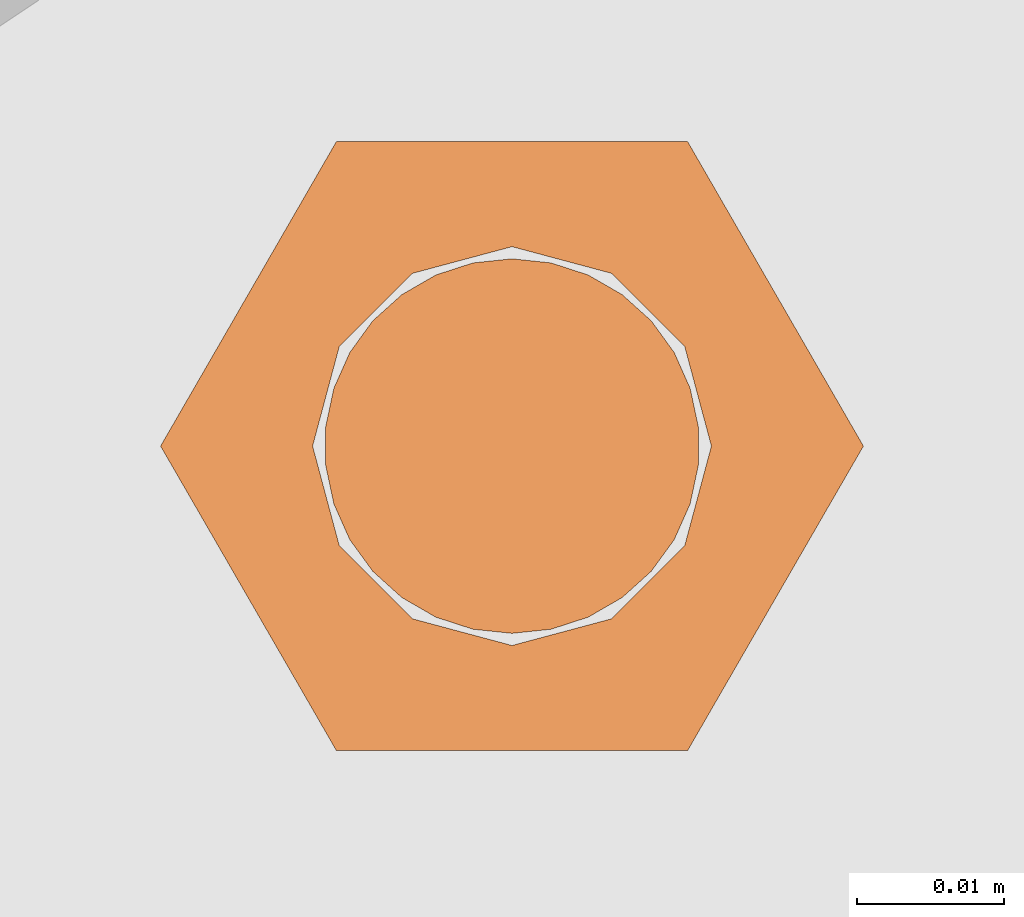
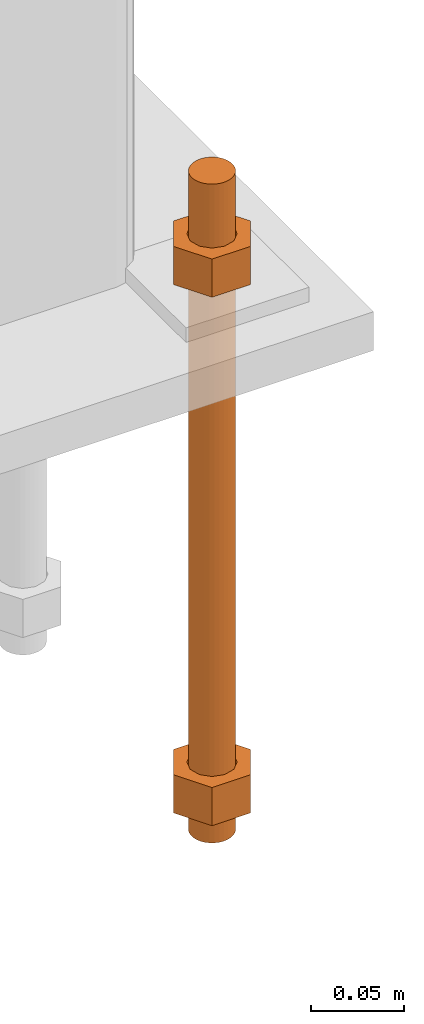
# One storey, part 29 of 89: 1 proxy.
"""IFC4 building model written with IfcOpenShell, lengths in feet."""

from ifc_helpers import new_model, entity, si_unit, converted_unit, derived_unit, direction, frame, origin, place, context, subcontext, project, spatial, faceted_brep, source, transform, mapped, material, constituent, constituent_set, type_object, type_shapes, element, save


model = new_model("IFC4")

# Units and contexts
model_context = context("Model", 3, precision=0.0001, world=origin(), true_north=direction((6.12303176911189e-17, 1.0)))
body_context = subcontext(model_context, "Body", "Model", "MODEL_VIEW")
ifc_project = project(units=[converted_unit("LENGTHUNIT", "FOOT", entity("IfcRatioMeasure", 0.3048), si_unit("LENGTHUNIT", "METRE"), dimensions=[1, 0, 0, 0, 0, 0, 0]), converted_unit("AREAUNIT", "SQUARE FOOT", entity("IfcRatioMeasure", 0.09290304), si_unit("AREAUNIT", "SQUARE_METRE"), dimensions=[2, 0, 0, 0, 0, 0, 0]), converted_unit("VOLUMEUNIT", "CUBIC FOOT", entity("IfcRatioMeasure", 0.028316846592), si_unit("VOLUMEUNIT", "CUBIC_METRE"), dimensions=[3, 0, 0, 0, 0, 0, 0]), si_unit("PLANEANGLEUNIT", "RADIAN"), si_unit("MASSUNIT", "GRAM", prefix="KILO"), derived_unit("MASSDENSITYUNIT", [(si_unit("MASSUNIT", "GRAM", prefix="KILO"), 1), (si_unit("LENGTHUNIT", "METRE"), -3)]), derived_unit("MOMENTOFINERTIAUNIT", [(si_unit("LENGTHUNIT", "METRE"), 4)]), si_unit("TIMEUNIT", "SECOND"), si_unit("FREQUENCYUNIT", "HERTZ"), si_unit("THERMODYNAMICTEMPERATUREUNIT", "DEGREE_CELSIUS"), derived_unit("THERMALTRANSMITTANCEUNIT", [(si_unit("MASSUNIT", "GRAM", prefix="KILO"), 1), (si_unit("THERMODYNAMICTEMPERATUREUNIT", "KELVIN"), -1), (si_unit("TIMEUNIT", "SECOND"), -3)]), derived_unit("VOLUMETRICFLOWRATEUNIT", [(si_unit("LENGTHUNIT", "METRE"), 3), (si_unit("TIMEUNIT", "SECOND"), -1)]), si_unit("ELECTRICCURRENTUNIT", "AMPERE"), si_unit("ELECTRICVOLTAGEUNIT", "VOLT"), si_unit("POWERUNIT", "WATT"), si_unit("FORCEUNIT", "NEWTON"), si_unit("ILLUMINANCEUNIT", "LUX"), si_unit("LUMINOUSFLUXUNIT", "LUMEN"), si_unit("LUMINOUSINTENSITYUNIT", "CANDELA"), derived_unit("USERDEFINED", [(si_unit("MASSUNIT", "GRAM", prefix="KILO"), -1), (si_unit("LENGTHUNIT", "METRE"), -2), (si_unit("TIMEUNIT", "SECOND"), 3), (si_unit("LUMINOUSFLUXUNIT", "LUMEN"), 1)]), derived_unit("LINEARVELOCITYUNIT", [(si_unit("LENGTHUNIT", "METRE"), 1), (si_unit("TIMEUNIT", "SECOND"), -1)]), si_unit("PRESSUREUNIT", "PASCAL"), derived_unit("USERDEFINED", [(si_unit("LENGTHUNIT", "METRE"), -2), (si_unit("MASSUNIT", "GRAM", prefix="KILO"), 1), (si_unit("TIMEUNIT", "SECOND"), -2)]), derived_unit("LINEARFORCEUNIT", [(si_unit("MASSUNIT", "GRAM", prefix="KILO"), 1), (si_unit("LENGTHUNIT", "METRE"), 1), (si_unit("TIMEUNIT", "SECOND"), -2), (si_unit("LENGTHUNIT", "METRE"), -1)]), derived_unit("PLANARFORCEUNIT", [(si_unit("MASSUNIT", "GRAM", prefix="KILO"), 1), (si_unit("LENGTHUNIT", "METRE"), 1), (si_unit("TIMEUNIT", "SECOND"), -2), (si_unit("LENGTHUNIT", "METRE"), -2)])], contexts=[model_context])

# Site, building, storey
site_placement = place(None, origin())
site = spatial("IfcSite", under=ifc_project, at=site_placement, CompositionType="ELEMENT")
building_placement = place(site_placement, frame((-472.238160486, -49.138065117, 0.0)))
building = spatial("IfcBuilding", under=site, at=building_placement, CompositionType="ELEMENT")
storey_placement = place(building_placement, origin())
storey = spatial("IfcBuildingStorey", under=building, at=storey_placement, Name="Level 1", CompositionType="ELEMENT", Elevation=0.0)

# Proxy
ifc_material_1 = material(Name="Color 7721", Category="Materials")
ifc_constituent_1 = constituent(ifc_material_1, Name="Color 7721", Category="Materials")
ifc_material_2 = material(Name="Color 7720", Category="Materials")
ifc_constituent_2 = constituent(ifc_material_2, Name="Color 7720", Category="Materials")
ifc_constituent_set = constituent_set(constituents=[ifc_constituent_1, ifc_constituent_2])
building_element_proxy_type = type_object("IfcBuildingElementProxyType", Name="rb2", PredefinedType="NOTDEFINED", material=ifc_material_1)
shared_shape = source(origin(), body_context, "Body", "Brep", [
    faceted_brep([(0.122545547339286, 0.0677083333333712, 0.0626666666666664), (0.156365697905557, 0.0677083333333712, 0.0626666666666664), (0.11727427342916, 0.135416666666742, 0.0626666666666664), (0.0390914244764247, 0.135416666666742, 0.0626666666666664), (0.0, 0.0677083333333712, 0.0626666666666664), (0.0338201505662994, 0.0677083333333712, 0.0626666666666664), (0.0397636251696838, 0.089889682526632, 0.0626666666666664), (0.0560014997595601, 0.106127557116452, 0.0626666666666664), (0.0781828489527925, 0.112071031719893, 0.0626666666666664), (0.100364198146025, 0.106127557116452, 0.0626666666666664), (0.116602072735901, 0.089889682526632, 0.0626666666666664), (0.11727427342916, 0.0, 0.0626666666666664), (0.0390914244764247, 0.0, 0.0626666666666664), (0.0397636251696838, 0.0455269841401105, 0.0626666666666664), (0.0560014997595601, 0.029289109550291, 0.0626666666666664), (0.0781828489527925, 0.0233456349468497, 0.0626666666666664), (0.100364198146025, 0.029289109550291, 0.0626666666666664), (0.116602072735901, 0.0455269841401105, 0.0626666666666664), (0.0, 0.0677083333333712, 0.144697916666667), (0.0390914244764531, 0.135416666666742, 0.144697916666667), (0.11727427342916, 0.135416666666742, 0.144697916666667), (0.156365697905585, 0.0677083333333712, 0.144697916666667), (0.117274273429189, 0.0, 0.144697916666667), (0.0390914244764247, 0.0, 0.144697916666667), (0.122545547339286, 0.0677083333333712, 0.144697916666666), (0.0338201505662994, 0.0677083333333712, 0.144697916666666), (0.0397636251696838, 0.0455269841401105, 0.144697916666666), (0.0560014997595601, 0.029289109550291, 0.144697916666666), (0.0781828489527925, 0.0233456349468497, 0.144697916666666), (0.100364198146025, 0.029289109550291, 0.144697916666666), (0.116602072735901, 0.0455269841401105, 0.144697916666666), (0.0397636251696838, 0.089889682526632, 0.144697916666666), (0.0560014997595601, 0.106127557116452, 0.144697916666666), (0.0781828489527925, 0.112071031719893, 0.144697916666666), (0.100364198146025, 0.106127557116452, 0.144697916666666), (0.116602072735901, 0.089889682526632, 0.144697916666666)], [[[0, 1, 2, 3, 4, 5, 6, 7, 8, 9, 10]], [[1, 11, 12, 4, 5, 13, 14, 15, 16, 17, 0]], [[4, 18, 19, 3]], [[3, 19, 20, 2]], [[2, 20, 21, 1]], [[1, 21, 22, 11]], [[11, 22, 23, 12]], [[12, 23, 18, 4]], [[24, 21, 22, 23, 18, 25, 26, 27, 28, 29, 30]], [[21, 20, 19, 18, 25, 31, 32, 33, 34, 35, 24]], [[25, 5, 6, 31]], [[31, 6, 7, 32]], [[32, 7, 8, 33]], [[33, 8, 9, 34]], [[34, 9, 10, 35]], [[35, 10, 0, 24]], [[24, 0, 17, 30]], [[30, 17, 16, 29]], [[29, 16, 15, 28]], [[28, 15, 14, 27]], [[27, 14, 13, 26]], [[26, 13, 5, 25]]]),
    faceted_brep([(0.0338201505662994, 0.0677083333333712, 1.28108333333333), (0.0, 0.0677083333333712, 1.28108333333333), (0.0390914244764247, 0.135416666666742, 1.28108333333333), (0.11727427342916, 0.135416666666742, 1.28108333333333), (0.156365697905557, 0.0677083333333712, 1.28108333333333), (0.122545547339286, 0.0677083333333712, 1.28108333333333), (0.116602072735901, 0.089889682526632, 1.28108333333333), (0.100364198146025, 0.106127557116452, 1.28108333333333), (0.0781828489527925, 0.112071031719893, 1.28108333333333), (0.0560014997595601, 0.106127557116452, 1.28108333333333), (0.0397636251696838, 0.089889682526632, 1.28108333333333), (0.0390914244764247, 0.0, 1.28108333333333), (0.11727427342916, 0.0, 1.28108333333333), (0.116602072735901, 0.0455269841401105, 1.28108333333333), (0.100364198146025, 0.029289109550291, 1.28108333333333), (0.0781828489527925, 0.0233456349468497, 1.28108333333333), (0.0560014997595601, 0.029289109550291, 1.28108333333333), (0.0397636251696838, 0.0455269841401105, 1.28108333333333), (0.156365697905528, 0.0677083333333712, 1.19905208333333), (0.117274273429132, 0.135416666666742, 1.19905208333333), (0.0390914244764247, 0.135416666666742, 1.19905208333333), (0.0, 0.0677083333333712, 1.19905208333333), (0.0390914244763962, 0.0, 1.19905208333333), (0.11727427342916, 0.0, 1.19905208333333), (0.0338201505662994, 0.0677083333333712, 1.19905208333333), (0.122545547339286, 0.0677083333333712, 1.19905208333333), (0.116602072735901, 0.0455269841401105, 1.19905208333333), (0.100364198146025, 0.029289109550291, 1.19905208333333), (0.0781828489527925, 0.0233456349468497, 1.19905208333333), (0.0560014997595601, 0.029289109550291, 1.19905208333333), (0.0397636251696838, 0.0455269841401105, 1.19905208333333), (0.116602072735901, 0.089889682526632, 1.19905208333333), (0.100364198146025, 0.106127557116452, 1.19905208333333), (0.0781828489527925, 0.112071031719893, 1.19905208333333), (0.0560014997595601, 0.106127557116452, 1.19905208333333), (0.0397636251696838, 0.089889682526632, 1.19905208333333)], [[[0, 1, 2, 3, 4, 5, 6, 7, 8, 9, 10]], [[1, 11, 12, 4, 5, 13, 14, 15, 16, 17, 0]], [[4, 18, 19, 3]], [[3, 19, 20, 2]], [[2, 20, 21, 1]], [[1, 21, 22, 11]], [[11, 22, 23, 12]], [[12, 23, 18, 4]], [[24, 21, 22, 23, 18, 25, 26, 27, 28, 29, 30]], [[21, 20, 19, 18, 25, 31, 32, 33, 34, 35, 24]], [[25, 5, 6, 31]], [[31, 6, 7, 32]], [[32, 7, 8, 33]], [[33, 8, 9, 34]], [[34, 9, 10, 35]], [[35, 10, 0, 24]], [[24, 0, 17, 30]], [[30, 17, 16, 29]], [[29, 16, 15, 28]], [[28, 15, 14, 27]], [[27, 14, 13, 26]], [[26, 13, 5, 25]]]),
    faceted_brep([(0.0781828489527925, 0.0260416666667425, 0.0), (0.0695198618353743, 0.0269521833027966, 0.0), (0.0612354888246216, 0.029643939264929, 0.0), (0.0536917967739328, 0.0339992919010683, 0.0), (0.0472184812245757, 0.0398278914017283, 0.0), (0.0420984571284464, 0.046875, 0.0), (0.0385554941071575, 0.0548326252344395, 0.0), (0.0367444366457903, 0.0633529806972319, 0.0), (0.0367444366457903, 0.0720636859695105, 0.0), (0.0385554941071575, 0.0805840414323029, 0.0), (0.0420984571284464, 0.0885416666667425, 0.0), (0.0472184812245757, 0.0955887752650142, 0.0), (0.0536917967739328, 0.101417374765674, 0.0), (0.0612354888246216, 0.105772727401813, 0.0), (0.0695198618353743, 0.108464483363946, 0.0), (0.0781828489527925, 0.109375, 0.0), (0.0868458360702107, 0.108464483363946, 0.0), (0.0951302090809634, 0.105772727401813, 0.0), (0.102673901131652, 0.101417374765674, 0.0), (0.109147216681009, 0.0955887752650142, 0.0), (0.114267240777139, 0.0885416666667425, 0.0), (0.117810203798427, 0.0805840414323029, 0.0), (0.119621261259795, 0.0720636859695105, 0.0), (0.119621261259795, 0.0633529806972319, 0.0), (0.117810203798427, 0.0548326252344395, 0.0), (0.114267240777139, 0.046875, 0.0), (0.109147216681009, 0.0398278914017283, 0.0), (0.102673901131652, 0.0339992919010683, 0.0), (0.0951302090809634, 0.029643939264929, 0.0), (0.0868458360702107, 0.0269521833027966, 0.0), (0.0868458360702107, 0.0269521833027966, 1.41666666666667), (0.0951302090809634, 0.029643939264929, 1.41666666666667), (0.102673901131652, 0.0339992919010683, 1.41666666666667), (0.109147216681009, 0.0398278914017283, 1.41666666666667), (0.114267240777139, 0.046875, 1.41666666666667), (0.117810203798427, 0.0548326252344395, 1.41666666666667), (0.119621261259795, 0.0633529806972319, 1.41666666666667), (0.119621261259795, 0.0720636859695105, 1.41666666666667), (0.117810203798427, 0.0805840414323029, 1.41666666666667), (0.114267240777139, 0.0885416666667425, 1.41666666666667), (0.109147216681009, 0.0955887752650142, 1.41666666666667), (0.102673901131652, 0.101417374765674, 1.41666666666667), (0.0951302090809634, 0.105772727401813, 1.41666666666667), (0.0868458360702107, 0.108464483363946, 1.41666666666667), (0.0781828489527925, 0.109375, 1.41666666666667), (0.0695198618353743, 0.108464483363946, 1.41666666666667), (0.0612354888246216, 0.105772727401813, 1.41666666666667), (0.0536917967739328, 0.101417374765674, 1.41666666666667), (0.0472184812245757, 0.0955887752650142, 1.41666666666667), (0.0420984571284464, 0.0885416666667425, 1.41666666666667), (0.0385554941071575, 0.0805840414323029, 1.41666666666667), (0.0367444366457903, 0.0720636859695105, 1.41666666666667), (0.0367444366457903, 0.0633529806972319, 1.41666666666667), (0.0385554941071575, 0.0548326252344395, 1.41666666666667), (0.0420984571284464, 0.046875, 1.41666666666667), (0.0472184812245757, 0.0398278914017283, 1.41666666666667), (0.0536917967739328, 0.0339992919010683, 1.41666666666667), (0.0612354888246216, 0.029643939264929, 1.41666666666667), (0.0695198618353743, 0.0269521833027966, 1.41666666666667), (0.0781828489527925, 0.0260416666667425, 1.41666666666667), (0.0695198618353743, 0.0269521833027966, 0.25), (0.0781828489527925, 0.0260416666667425, 0.25), (0.0612354888246216, 0.029643939264929, 0.25), (0.0536917967739328, 0.0339992919010683, 0.25), (0.0472184812246326, 0.0398278914017283, 0.25), (0.0420984571284464, 0.046875, 0.25), (0.0385554941071575, 0.0548326252344395, 0.25), (0.0367444366457619, 0.0633529806972319, 0.25), (0.0367444366457903, 0.0720636859695105, 0.25), (0.0385554941071575, 0.0805840414323029, 0.25), (0.0420984571284464, 0.0885416666667425, 0.25), (0.0472184812245757, 0.0955887752650142, 0.25), (0.0536917967739612, 0.101417374765674, 0.25), (0.0612354888246216, 0.105772727401813, 0.25), (0.0695198618353743, 0.108464483363946, 0.25), (0.0781828489527925, 0.109375, 0.25), (0.0868458360702107, 0.108464483363946, 0.25), (0.0951302090809634, 0.105772727401813, 0.25), (0.102673901131652, 0.101417374765674, 0.25), (0.109147216681038, 0.0955887752650142, 0.25), (0.114267240777139, 0.0885416666667425, 0.25), (0.117810203798371, 0.0805840414323029, 0.25), (0.119621261259795, 0.0720636859695105, 0.25), (0.119621261259795, 0.0633529806972319, 0.25), (0.117810203798399, 0.0548326252344395, 0.25), (0.114267240777195, 0.046875, 0.25), (0.109147216681009, 0.0398278914017283, 0.25), (0.102673901131709, 0.0339992919010683, 0.25), (0.0951302090809634, 0.029643939264929, 0.25), (0.0868458360702107, 0.0269521833027966, 0.25), (0.0695198618353743, 0.0269521833027966, 0.916666666666667), (0.0781828489527925, 0.0260416666667425, 0.916666666666667), (0.0612354888246216, 0.029643939264929, 0.916666666666667), (0.0536917967739328, 0.0339992919010683, 0.916666666666667), (0.0472184812246326, 0.0398278914017283, 0.916666666666667), (0.0420984571284464, 0.046875, 0.916666666666667), (0.0385554941071575, 0.0548326252344395, 0.916666666666667), (0.0367444366457619, 0.0633529806972319, 0.916666666666667), (0.0367444366457903, 0.0720636859695105, 0.916666666666667), (0.0385554941071575, 0.0805840414323029, 0.916666666666667), (0.0420984571284464, 0.0885416666667425, 0.916666666666667), (0.0472184812245757, 0.0955887752650142, 0.916666666666667), (0.0536917967739612, 0.101417374765674, 0.916666666666667), (0.0612354888246216, 0.105772727401813, 0.916666666666667), (0.0695198618353743, 0.108464483363946, 0.916666666666667), (0.0781828489527925, 0.109375, 0.916666666666667), (0.0868458360702107, 0.108464483363946, 0.916666666666667), (0.0951302090809634, 0.105772727401813, 0.916666666666667), (0.102673901131652, 0.101417374765674, 0.916666666666667), (0.109147216681038, 0.0955887752650142, 0.916666666666667), (0.114267240777139, 0.0885416666667425, 0.916666666666667), (0.117810203798371, 0.0805840414323029, 0.916666666666667), (0.119621261259795, 0.0720636859695105, 0.916666666666667), (0.119621261259795, 0.0633529806972319, 0.916666666666667), (0.117810203798399, 0.0548326252344395, 0.916666666666667), (0.114267240777195, 0.046875, 0.916666666666667), (0.109147216681009, 0.0398278914017283, 0.916666666666667), (0.102673901131709, 0.0339992919010683, 0.916666666666667), (0.0951302090809634, 0.029643939264929, 0.916666666666667), (0.0868458360702107, 0.0269521833027966, 0.916666666666667)], [[[0, 1, 2, 3, 4, 5, 6, 7, 8, 9, 10, 11, 12, 13, 14, 15, 16, 17, 18, 19, 20, 21, 22, 23, 24, 25, 26, 27, 28, 29]], [[30, 31, 32, 33, 34, 35, 36, 37, 38, 39, 40, 41, 42, 43, 44, 45, 46, 47, 48, 49, 50, 51, 52, 53, 54, 55, 56, 57, 58, 59]], [[60, 1, 0, 61]], [[62, 2, 1, 60]], [[63, 3, 2, 62]], [[64, 4, 3, 63]], [[65, 5, 4, 64]], [[66, 6, 5, 65]], [[67, 7, 6, 66]], [[68, 8, 7, 67]], [[69, 9, 8, 68]], [[70, 10, 9, 69]], [[71, 11, 10, 70]], [[72, 12, 11, 71]], [[73, 13, 12, 72]], [[74, 14, 13, 73]], [[75, 15, 14, 74]], [[76, 16, 15, 75]], [[77, 17, 16, 76]], [[78, 18, 17, 77]], [[79, 19, 18, 78]], [[80, 20, 19, 79]], [[81, 21, 20, 80]], [[82, 22, 21, 81]], [[83, 23, 22, 82]], [[84, 24, 23, 83]], [[85, 25, 24, 84]], [[86, 26, 25, 85]], [[87, 27, 26, 86]], [[88, 28, 27, 87]], [[89, 29, 28, 88]], [[61, 0, 29, 89]], [[90, 60, 61, 91]], [[92, 62, 60, 90]], [[93, 63, 62, 92]], [[94, 64, 63, 93]], [[95, 65, 64, 94]], [[96, 66, 65, 95]], [[97, 67, 66, 96]], [[98, 68, 67, 97]], [[99, 69, 68, 98]], [[100, 70, 69, 99]], [[101, 71, 70, 100]], [[102, 72, 71, 101]], [[103, 73, 72, 102]], [[104, 74, 73, 103]], [[105, 75, 74, 104]], [[106, 76, 75, 105]], [[107, 77, 76, 106]], [[108, 78, 77, 107]], [[109, 79, 78, 108]], [[110, 80, 79, 109]], [[111, 81, 80, 110]], [[112, 82, 81, 111]], [[113, 83, 82, 112]], [[114, 84, 83, 113]], [[115, 85, 84, 114]], [[116, 86, 85, 115]], [[117, 87, 86, 116]], [[118, 88, 87, 117]], [[119, 89, 88, 118]], [[91, 61, 89, 119]], [[58, 90, 91, 59]], [[57, 92, 90, 58]], [[56, 93, 92, 57]], [[55, 94, 93, 56]], [[54, 95, 94, 55]], [[53, 96, 95, 54]], [[52, 97, 96, 53]], [[51, 98, 97, 52]], [[50, 99, 98, 51]], [[49, 100, 99, 50]], [[48, 101, 100, 49]], [[47, 102, 101, 48]], [[46, 103, 102, 47]], [[45, 104, 103, 46]], [[44, 105, 104, 45]], [[43, 106, 105, 44]], [[42, 107, 106, 43]], [[41, 108, 107, 42]], [[40, 109, 108, 41]], [[39, 110, 109, 40]], [[38, 111, 110, 39]], [[37, 112, 111, 38]], [[36, 113, 112, 37]], [[35, 114, 113, 36]], [[34, 115, 114, 35]], [[33, 116, 115, 34]], [[32, 117, 116, 33]], [[31, 118, 117, 32]], [[30, 119, 118, 31]], [[59, 91, 119, 30]]]),
])
type_shapes(building_element_proxy_type, [shared_shape])
proxy_placement = place(building_placement, frame((200.25515048438, 999.598958333333, -1.45833333333333)))
element("IfcBuildingElementProxy", 1, at=proxy_placement, inside=storey, type_object=building_element_proxy_type, material=ifc_constituent_set, Name="rb2 477:rb2 477", ObjectType="rb2 477:rb2 477", PredefinedType="NOTDEFINED", context=body_context, shape_type="MappedRepresentation", body=[
    mapped(shared_shape, transform((0.0, 0.0, 0.0), scale=1.0)),
])

save(model, "model.ifc")
